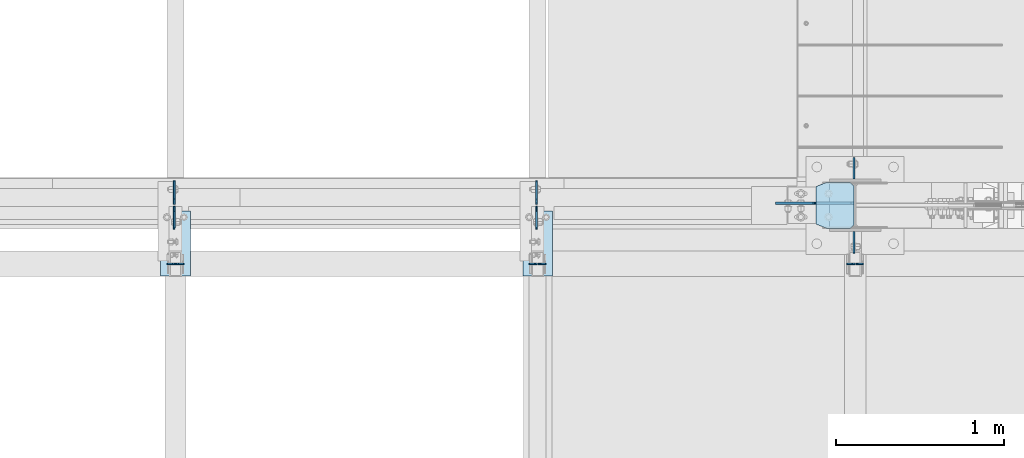
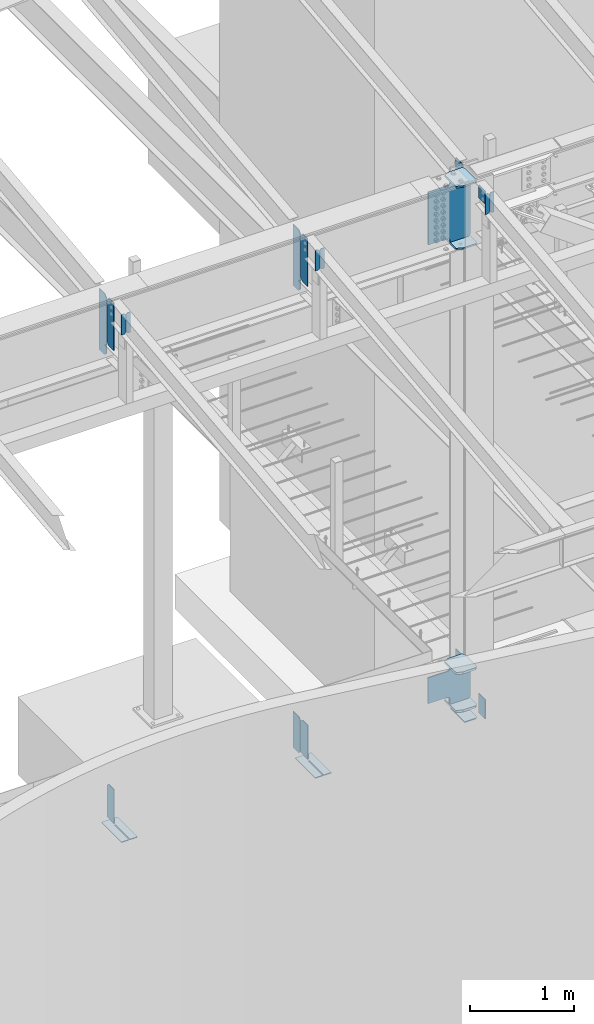
# One storey, part 997 of 1179: 26 plates, 8 elements without a shape of their own.
"""IFC2X3 building model written with IfcOpenShell, lengths in millimetres."""

from ifc_helpers import new_model, si_unit, frame, origin_with_axes, place, context, subcontext, project, spatial, faceted_brep, material, type_object, element, aggregate, save


model = new_model("IFC2X3")

# Units and contexts
model_context = context("Model", 3, precision=1e-05, world=origin_with_axes())
body_context = subcontext(model_context, "Body", "Model", "MODEL_VIEW")
ifc_project = project(units=[si_unit("LENGTHUNIT", "METRE", prefix="MILLI"), si_unit("AREAUNIT", "SQUARE_METRE"), si_unit("VOLUMEUNIT", "CUBIC_METRE"), si_unit("MASSUNIT", "GRAM", prefix="KILO"), si_unit("TIMEUNIT", "SECOND"), si_unit("PLANEANGLEUNIT", "RADIAN"), si_unit("SOLIDANGLEUNIT", "STERADIAN"), si_unit("THERMODYNAMICTEMPERATUREUNIT", "DEGREE_CELSIUS"), si_unit("LUMINOUSINTENSITYUNIT", "LUMEN")], contexts=[model_context])

# Site, building, storey
site_placement = place(None, origin_with_axes())
site = spatial("IfcSite", under=ifc_project, at=site_placement, CompositionType="ELEMENT")
building_placement = place(site_placement, origin_with_axes())
building = spatial("IfcBuilding", under=site, at=building_placement, Name="Undefined", CompositionType="ELEMENT")
storey_placement = place(building_placement, origin_with_axes())
storey = spatial("IfcBuildingStorey", under=building, at=storey_placement, Name="Undefined", CompositionType="ELEMENT", Elevation=0.0)

# Assembly, plates
assembly_1_placement = place(storey_placement, origin_with_axes())
assembly_1 = element("IfcElementAssembly", 1, at=assembly_1_placement, inside=storey, Name="COLUMN", AssemblyPlace="NOTDEFINED", PredefinedType="RIGID_FRAME")
ifc_material_1 = material(Name="STEEL/A36")
plate_type_1 = type_object("IfcPlateType", PredefinedType="NOTDEFINED")
plate_1_placement = place(assembly_1_placement, frame((16452.05625, 5592.76250000006, 9850.31550933372), z_axis=(0.0, 1.0, 0.0), x_axis=(0.0, 0.0, -1.0)))
plate_1 = element("IfcPlate", 2, at=plate_1_placement, type_object=plate_type_1, material=ifc_material_1, Name="PLATE", context=body_context, shape_type="Brep", body=[
    faceted_brep([(0.0, -4.76249999999709, 0.0), (0.0, -4.76249999999709, 127.0), (0.0, 4.76249999999709, 127.0), (0.0, 4.76249999999709, 0.0), (228.6, -4.76249999999709, 127.0), (228.6, 4.76249999999709, 127.0), (228.6, -4.76249999999709, 0.0), (228.6, 4.76249999999709, 0.0)], [[[0, 1, 2, 3]], [[1, 4, 5, 2]], [[4, 6, 7, 5]], [[6, 0, 3, 7]], [[5, 7, 3, 2]], [[6, 4, 1, 0]]]),
])
plate_2_placement = place(assembly_1_placement, frame((16452.05625, 5278.43749999996, 9794.70652310487), z_axis=(0.0, -1.0, 0.0), x_axis=(0.0, 0.0, -1.0)))
plate_2 = element("IfcPlate", 3, at=plate_2_placement, type_object=plate_type_1, material=ifc_material_1, Name="PLATE", context=body_context, shape_type="Brep", body=[
    faceted_brep([(0.0, -4.76249999999709, 0.0), (0.0, -4.76249999999709, 127.0), (0.0, 4.76249999999709, 127.0), (0.0, 4.76249999999709, 0.0), (152.4, -4.76250000000073, 127.0), (152.4, 4.76250000000073, 127.0), (152.4, -4.76250000000073, 0.0), (152.4, 4.76250000000073, 0.0)], [[[0, 1, 2, 3]], [[1, 4, 5, 2]], [[4, 6, 7, 5]], [[6, 0, 3, 7]], [[5, 7, 3, 2]], [[6, 4, 1, 0]]]),
])

assembly_2_placement = place(storey_placement, origin_with_axes())
assembly_2 = element("IfcElementAssembly", 4, at=assembly_2_placement, inside=storey, Name="BEAM", AssemblyPlace="NOTDEFINED", PredefinedType="RIGID_FRAME")
plate_3_placement = place(assembly_2_placement, frame((14559.7557500839, 5429.25933465636, 9245.8912842795), z_axis=(0.0, 0.0, 1.0), x_axis=(0.0, -1.0, 0.0)))
plate_3 = element("IfcPlate", 5, at=plate_3_placement, type_object=plate_type_1, material=ifc_material_1, Name="PLATE", context=body_context, shape_type="Brep", body=[
    faceted_brep([(1.81898940354586e-12, -4.76249999999709, 31.75), (0.0, -4.76250000000073, 531.8125), (0.0, 4.76250000000073, 531.8125), (-1.81898940354586e-12, 4.76249999998981, 31.75), (31.75, -4.76250000000073, 563.5625), (31.75, 4.76250000000073, 563.5625), (127.0, -4.76250000000073, 563.5625), (127.0, 4.76250000000073, 563.5625), (127.0, -4.76250000000073, 0.0), (127.0, 4.76250000000073, 0.0), (31.7499999988213, -4.76250000001164, 0.0), (31.7499999988249, 4.76249999998254, 0.0)], [[[0, 1, 2, 3]], [[1, 4, 5, 2]], [[4, 6, 7, 5]], [[6, 8, 9, 7]], [[8, 10, 11, 9]], [[10, 0, 3, 11]], [[5, 7, 9, 11, 3, 2]], [[10, 8, 6, 4, 1, 0]]]),
])
plate_4_placement = place(assembly_2_placement, frame((12400.7557500839, 5429.25933465636, 9245.8912842795), z_axis=(0.0, 0.0, 1.0), x_axis=(0.0, -1.0, 0.0)))
plate_4 = element("IfcPlate", 6, at=plate_4_placement, type_object=plate_type_1, material=ifc_material_1, Name="PLATE", context=body_context, shape_type="Brep", body=[
    faceted_brep([(1.81898940354586e-12, -4.76249999999709, 31.75), (0.0, -4.76250000000073, 531.8125), (0.0, 4.76250000000073, 531.8125), (-1.81898940354586e-12, 4.76249999998981, 31.75), (31.75, -4.76250000000073, 563.5625), (31.75, 4.76250000000073, 563.5625), (127.0, -4.76250000000073, 563.5625), (127.0, 4.76250000000073, 563.5625), (127.0, -4.76250000000073, 0.0), (127.0, 4.76250000000073, 0.0), (31.7499999988213, -4.76250000001164, 0.0), (31.7499999988249, 4.76249999998254, 0.0)], [[[0, 1, 2, 3]], [[1, 4, 5, 2]], [[4, 6, 7, 5]], [[6, 8, 9, 7]], [[8, 10, 11, 9]], [[10, 0, 3, 11]], [[5, 7, 9, 11, 3, 2]], [[10, 8, 6, 4, 1, 0]]]),
])

# Plate
plate_5_placement = place(assembly_1_placement, frame((16451.2625017882, 5278.43749999682, 3810.0), z_axis=(0.0, -1.0, 0.0), x_axis=(0.0, 0.0, -1.0)))
plate_5 = element("IfcPlate", 7, at=plate_5_placement, type_object=plate_type_1, material=ifc_material_1, Name="PLATE", context=body_context, shape_type="Brep", body=[
    faceted_brep([(0.0, -4.76249999999709, 0.0), (0.0, -4.76249999999709, 127.0), (0.0, 4.76249999999709, 127.0), (0.0, 4.76249999999709, 0.0), (228.6, -4.76249999999709, 127.0), (228.6, 4.76249999999709, 127.0), (228.6, -4.76249999999709, 0.0), (228.6, 4.76249999999709, 0.0)], [[[0, 1, 2, 3]], [[1, 4, 5, 2]], [[4, 6, 7, 5]], [[6, 0, 3, 7]], [[5, 7, 3, 2]], [[6, 4, 1, 0]]]),
])

plate_6_placement = place(assembly_1_placement, frame((16451.2625, 5592.7625, 4063.99999886453), z_axis=(0.0, 1.0, 0.0), x_axis=(0.0, 0.0, -1.0)))
plate_6 = element("IfcPlate", 8, at=plate_6_placement, type_object=plate_type_1, material=ifc_material_1, Name="PLATE", context=body_context, shape_type="Brep", body=[
    faceted_brep([(0.0, -4.76249999999709, 0.0), (0.0, -4.76249999999709, 127.0), (0.0, 4.76249999999709, 127.0), (0.0, 4.76249999999709, 0.0), (304.799999999999, -4.76249999999982, 127.0), (304.799999999999, 4.76249999999982, 127.0), (304.799987792969, -4.76250000000073, 0.0), (304.799987792969, 4.76250000000073, 0.0)], [[[0, 1, 2, 3]], [[2, 1, 4, 5]], [[4, 6, 7, 5]], [[6, 0, 3, 7]], [[5, 7, 3, 2]], [[6, 4, 1, 0]]]),
])

# Assembly, plates
assembly_3_placement = place(storey_placement, origin_with_axes())
assembly_3 = element("IfcElementAssembly", 9, at=assembly_3_placement, inside=storey, Name="BEAM", AssemblyPlace="NOTDEFINED", PredefinedType="RIGID_FRAME")
plate_type_2 = type_object("IfcPlateType", PredefinedType="NOTDEFINED")
plate_7_placement = place(assembly_3_placement, frame((14558.9624967425, 5576.9753907878, 3652.8375), z_axis=(0.0, 0.0, 1.0), x_axis=(0.0, -1.0, 0.0)))
plate_7 = element("IfcPlate", 10, at=plate_7_placement, type_object=plate_type_2, material=ifc_material_1, Name="PLATE", context=body_context, shape_type="Brep", body=[
    faceted_brep([(0.0, -4.76249999999709, 0.0), (-9.09494701772928e-13, -4.76250000000255, 425.450012207031), (9.09494701772928e-13, 4.76249999999891, 425.450012207031), (0.0, 4.76249999999709, 0.0), (108.743890762328, -4.76250000002983, 425.450012207031), (108.743890762331, 4.7624999999698, 425.450012207031), (134.143890380858, -4.76250000003529, 400.050012588501), (134.143890380861, 4.76249999996435, 400.050012588501), (134.143890380858, -4.76250000003529, 25.3999996185303), (134.143890380861, 4.76249999996435, 25.3999996185303), (108.743890762328, -4.76250000002983, 0.0), (108.743890762331, 4.7624999999698, 0.0)], [[[0, 1, 2, 3]], [[1, 4, 5, 2]], [[4, 6, 7, 5]], [[6, 8, 9, 7]], [[8, 10, 11, 9]], [[10, 0, 3, 11]], [[5, 7, 9, 11, 3, 2]], [[10, 8, 6, 4, 1, 0]]]),
])
plate_8_placement = place(assembly_3_placement, frame((14558.9624998093, 5294.3125001143, 3683.00001220703), z_axis=(0.0, 0.0, 1.0), x_axis=(0.0, 1.0, 0.0)))
plate_8 = element("IfcPlate", 11, at=plate_8_placement, type_object=plate_type_2, material=ifc_material_1, Name="PLATE", context=body_context, shape_type="Brep", body=[
    faceted_brep([(0.0, -4.76249999999709, 0.0), (1.81898940354586e-12, -4.76250000000437, 396.875), (0.0, 4.762500000008, 396.875), (0.0, 4.76249999999709, 0.0), (108.74389076233, -4.76249999996799, 396.875), (108.743890762327, 4.76250000003165, 396.875), (134.14389038086, -4.76249999996253, 371.47500038147), (134.143890380858, 4.76250000003711, 371.47500038147), (134.14389038086, -4.76249999996253, 0.0), (134.143890380858, 4.76250000003711, 0.0)], [[[0, 1, 2, 3]], [[1, 4, 5, 2]], [[4, 6, 7, 5]], [[6, 8, 9, 7]], [[8, 0, 3, 9]], [[5, 7, 9, 3, 2]], [[8, 6, 4, 1, 0]]]),
])
plate_9_placement = place(assembly_3_placement, frame((12399.9624967425, 5294.3125001143, 3683.00001220703), z_axis=(0.0, 0.0, 1.0), x_axis=(0.0, 1.0, 0.0)))
plate_9 = element("IfcPlate", 12, at=plate_9_placement, type_object=plate_type_2, material=ifc_material_1, Name="PLATE", context=body_context, shape_type="Brep", body=[
    faceted_brep([(0.0, -4.76249999999709, 0.0), (1.81898940354586e-12, -4.76250000000437, 396.875), (0.0, 4.762500000008, 396.875), (0.0, 4.76249999999709, 0.0), (108.74389076233, -4.76249999996799, 396.875), (108.743890762327, 4.76250000003165, 396.875), (134.14389038086, -4.76249999996253, 371.47500038147), (134.143890380858, 4.76250000003711, 371.47500038147), (134.14389038086, -4.76249999996253, 0.0), (134.143890380858, 4.76250000003711, 0.0)], [[[0, 1, 2, 3]], [[1, 4, 5, 2]], [[4, 6, 7, 5]], [[6, 8, 9, 7]], [[8, 0, 3, 9]], [[5, 7, 9, 3, 2]], [[8, 6, 4, 1, 0]]]),
])
aggregate(assembly_3, [plate_7, plate_8, plate_9])

# Plate
plate_type_3 = type_object("IfcPlateType", PredefinedType="NOTDEFINED")
plate_10_placement = place(assembly_2_placement, frame((14559.7557500839, 5441.95933465636, 9095.0787842795), z_axis=(0.0, 0.0, 1.0), x_axis=(0.0, 1.0, 0.0)))
plate_10 = element("IfcPlate", 13, at=plate_10_placement, type_object=plate_type_3, material=ifc_material_1, Name="PLATE", context=body_context, shape_type="Brep", body=[
    faceted_brep([(1.81898940354586e-12, -4.76249999999709, 31.75), (0.0, -4.76249999999982, 682.625), (0.0, 4.76249999999982, 682.625), (-1.81898940354586e-12, 4.76249999998981, 31.75), (31.75, -4.76249999999982, 714.375), (31.75, 4.76249999999982, 714.375), (139.7, -4.76249999999982, 714.375), (139.7, 4.76249999999982, 714.375), (139.7, -4.76249999999982, 0.0), (139.7, 4.76249999999982, 0.0), (31.7499999988213, -4.76250000001164, 0.0), (31.7499999988249, 4.76249999998254, 0.0)], [[[0, 1, 2, 3]], [[1, 4, 5, 2]], [[4, 6, 7, 5]], [[6, 8, 9, 7]], [[8, 10, 11, 9]], [[10, 0, 3, 11]], [[5, 7, 9, 11, 3, 2]], [[10, 8, 6, 4, 1, 0]]]),
])

plate_11_placement = place(assembly_2_placement, frame((12400.7557500839, 5441.95933465636, 9095.0787842795), z_axis=(0.0, 0.0, 1.0), x_axis=(0.0, 1.0, 0.0)))
plate_11 = element("IfcPlate", 14, at=plate_11_placement, type_object=plate_type_3, material=ifc_material_1, Name="PLATE", context=body_context, shape_type="Brep", body=[
    faceted_brep([(1.81898940354586e-12, -4.76249999999709, 31.75), (0.0, -4.76249999999982, 682.625), (0.0, 4.76249999999982, 682.625), (-1.81898940354586e-12, 4.76249999998981, 31.75), (31.75, -4.76249999999982, 714.375), (31.75, 4.76249999999982, 714.375), (139.7, -4.76249999999982, 714.375), (139.7, 4.76249999999982, 714.375), (139.7, -4.76249999999982, 0.0), (139.7, 4.76249999999982, 0.0), (31.7499999988213, -4.76250000001164, 0.0), (31.7499999988249, 4.76249999998254, 0.0)], [[[0, 1, 2, 3]], [[1, 4, 5, 2]], [[4, 6, 7, 5]], [[6, 8, 9, 7]], [[8, 10, 11, 9]], [[10, 0, 3, 11]], [[5, 7, 9, 11, 3, 2]], [[10, 8, 6, 4, 1, 0]]]),
])

aggregate(assembly_2, [plate_3, plate_10, plate_4, plate_11])

# Assembly, plate
assembly_4_placement = place(storey_placement, origin_with_axes())
assembly_4 = element("IfcElementAssembly", 15, at=assembly_4_placement, inside=storey, Name="BEAM", AssemblyPlace="NOTDEFINED", PredefinedType="RIGID_FRAME")
plate_type_4 = type_object("IfcPlateType", PredefinedType="NOTDEFINED")
plate_12_placement = place(assembly_4_placement, frame((14655.8000024381, 5403.05638849583, 3656.0125), z_axis=(0.0, -1.0, 0.0), x_axis=(-1.0, 0.0, 0.0)))
plate_12 = element("IfcPlate", 16, at=plate_12_placement, type_object=plate_type_4, material=ifc_material_1, Name="PLATE", context=body_context, shape_type="Brep", body=[
    faceted_brep([(84.1374995226361, -4.76249999999982, 388.143896484398), (84.1374998016308, -4.76249999999982, 108.743890683401), (84.1374998016308, 4.76249999999982, 108.743890683401), (84.1374995226361, 4.76249999999982, 388.143896484398), (93.6624994201611, -4.76249999999982, 108.743890698304), (93.6624994201611, 4.76249999999982, 108.743890698304), (93.6624981874847, -4.76249999999982, 388.143890669526), (93.6624981874847, 4.76249999999982, 388.143896484401), (0.0, -4.76249999999709, 0.0), (-1.44472687679809e-06, -4.76249999999982, 388.143896484375), (-1.44472687679809e-06, 4.76249999999982, 388.143896484375), (0.0, 4.76249999999709, 0.0), (177.800003051758, -4.76249999999982, 0.0), (177.800003051758, 4.76249999999982, 0.0), (177.799987133836, -4.76249999999982, 388.143896484426), (177.799987133836, 4.76249999999982, 388.143896484426)], [[[0, 1, 2, 3]], [[4, 5, 2, 1]], [[6, 7, 5, 4]], [[8, 9, 10, 11]], [[12, 8, 11, 13]], [[14, 12, 13, 15]], [[1, 0, 9, 8, 12, 14, 6, 4]], [[10, 9, 0, 3]], [[15, 13, 11, 10, 3, 2, 5, 7]], [[14, 15, 7, 6]]]),
])
aggregate(assembly_4, [plate_12])

assembly_5_placement = place(storey_placement, origin_with_axes())
assembly_5 = element("IfcElementAssembly", 17, at=assembly_5_placement, inside=storey, Name="BEAM", AssemblyPlace="NOTDEFINED", PredefinedType="RIGID_FRAME")
plate_13_placement = place(assembly_5_placement, frame((12496.7999993714, 5403.05638849583, 3656.0125), z_axis=(0.0, -1.0, 0.0), x_axis=(-1.0, 0.0, 0.0)))
plate_13 = element("IfcPlate", 18, at=plate_13_placement, type_object=plate_type_4, material=ifc_material_1, Name="PLATE", context=body_context, shape_type="Brep", body=[
    faceted_brep([(84.1374995226361, -4.76249999999982, 388.143896484398), (84.1374998016308, -4.76249999999982, 108.743890683401), (84.1374998016308, 4.76249999999982, 108.743890683401), (84.1374995226361, 4.76249999999982, 388.143896484398), (93.6624994201611, -4.76249999999982, 108.743890698304), (93.6624994201611, 4.76249999999982, 108.743890698304), (93.6624981874847, -4.76249999999982, 388.143890669526), (93.6624981874847, 4.76249999999982, 388.143896484401), (0.0, -4.76249999999709, 0.0), (-1.44472687679809e-06, -4.76249999999982, 388.143896484375), (-1.44472687679809e-06, 4.76249999999982, 388.143896484375), (0.0, 4.76249999999709, 0.0), (177.800003051758, -4.76249999999982, 0.0), (177.800003051758, 4.76249999999982, 0.0), (177.799987133836, -4.76249999999982, 388.143896484426), (177.799987133836, 4.76249999999982, 388.143896484426)], [[[0, 1, 2, 3]], [[4, 5, 2, 1]], [[6, 7, 5, 4]], [[8, 9, 10, 11]], [[12, 8, 11, 13]], [[14, 12, 13, 15]], [[1, 0, 9, 8, 12, 14, 6, 4]], [[10, 9, 0, 3]], [[15, 13, 11, 10, 3, 2, 5, 7]], [[14, 15, 7, 6]]]),
])
aggregate(assembly_5, [plate_13])

# Assembly, plates
assembly_6_placement = place(storey_placement, origin_with_axes())
assembly_6 = element("IfcElementAssembly", 19, at=assembly_6_placement, inside=storey, Name="BEAM", AssemblyPlace="NOTDEFINED", PredefinedType="RIGID_FRAME")
plate_type_5 = type_object("IfcPlateType", PredefinedType="NOTDEFINED")
plate_14_placement = place(assembly_6_placement, frame((16409.9875, 5086.35, 9814.71314162917), z_axis=(0.0, 0.0, -1.0), x_axis=(1.0, 0.0, 0.0)))
plate_14 = element("IfcPlate", 20, at=plate_14_placement, type_object=plate_type_5, material=ifc_material_1, Name="PLATE", context=body_context, shape_type="Brep", body=[
    faceted_brep([(0.0, -4.76249999999709, 0.0), (0.0, -4.76249999999982, 240.171811375247), (0.0, 4.76249999999982, 240.171811375247), (0.0, 4.76249999999709, 0.0), (30.9562500000029, -4.76249999999982, 240.171811375247), (30.9562500000029, 4.76249999999982, 240.171811375247), (46.8312500000029, -4.76249999999982, 224.296811375247), (46.8312500000029, 4.76249999999982, 224.296811375247), (46.8312500000029, -4.76249999999982, 15.875), (46.8312500000029, 4.76249999999982, 15.875), (30.9562500000029, -4.76249999999982, 0.0), (30.9562500000029, 4.76249999999982, 0.0)], [[[0, 1, 2, 3]], [[1, 4, 5, 2]], [[4, 6, 7, 5]], [[6, 8, 9, 7]], [[8, 10, 11, 9]], [[10, 0, 3, 11]], [[5, 7, 9, 11, 3, 2]], [[10, 8, 6, 4, 1, 0]]]),
])
plate_15_placement = place(assembly_6_placement, frame((16461.58125, 5086.35, 9814.71314162917), z_axis=(0.0, 0.0, -1.0), x_axis=(1.0, 0.0, 0.0)))
plate_15 = element("IfcPlate", 21, at=plate_15_placement, type_object=plate_type_5, material=ifc_material_1, Name="PLATE", context=body_context, shape_type="Brep", body=[
    faceted_brep([(-1.81898940354586e-12, -4.76249999999936, 15.875), (0.0, -4.76249999999982, 224.296811375247), (0.0, 4.76249999999982, 224.296811375247), (1.81898940354586e-12, 4.76249999999936, 15.875), (15.875, -4.76249999999982, 240.171811375247), (15.875, 4.76249999999982, 240.171811375247), (46.8312500000029, -4.76249999999982, 240.171811375247), (46.8312500000029, 4.76249999999982, 240.171811375247), (46.8312500000029, -4.76249999999982, 0.0), (46.8312500000029, 4.76249999999982, 0.0), (15.8749999999891, -4.76249999999845, 0.0), (15.8749999999945, 4.76250000000027, 0.0)], [[[0, 1, 2, 3]], [[1, 4, 5, 2]], [[4, 6, 7, 5]], [[6, 8, 9, 7]], [[8, 10, 11, 9]], [[10, 0, 3, 11]], [[5, 7, 9, 11, 3, 2]], [[10, 8, 6, 4, 1, 0]]]),
])
aggregate(assembly_6, [plate_14, plate_15])

assembly_7_placement = place(storey_placement, origin_with_axes())
assembly_7 = element("IfcElementAssembly", 22, at=assembly_7_placement, inside=storey, Name="BEAM", AssemblyPlace="NOTDEFINED", PredefinedType="RIGID_FRAME")
plate_16_placement = place(assembly_7_placement, frame((14517.6875, 5086.35, 9814.71314162916), z_axis=(0.0, 0.0, -1.0), x_axis=(1.0, 0.0, 0.0)))
plate_16 = element("IfcPlate", 23, at=plate_16_placement, type_object=plate_type_5, material=ifc_material_1, Name="PLATE", context=body_context, shape_type="Brep", body=[
    faceted_brep([(0.0, -4.76249999999709, 0.0), (0.0, -4.76249999999982, 240.171811375247), (0.0, 4.76249999999982, 240.171811375247), (0.0, 4.76249999999709, 0.0), (30.9562500000029, -4.76249999999982, 240.171811375247), (30.9562500000029, 4.76249999999982, 240.171811375247), (46.8312500000029, -4.76249999999982, 224.296811375247), (46.8312500000029, 4.76249999999982, 224.296811375247), (46.8312500000029, -4.76249999999982, 15.875), (46.8312500000029, 4.76249999999982, 15.875), (30.9562500000029, -4.76249999999982, 0.0), (30.9562500000029, 4.76249999999982, 0.0)], [[[0, 1, 2, 3]], [[1, 4, 5, 2]], [[4, 6, 7, 5]], [[6, 8, 9, 7]], [[8, 10, 11, 9]], [[10, 0, 3, 11]], [[5, 7, 9, 11, 3, 2]], [[10, 8, 6, 4, 1, 0]]]),
])
plate_17_placement = place(assembly_7_placement, frame((14569.28125, 5086.35, 9814.71314162916), z_axis=(0.0, 0.0, -1.0), x_axis=(1.0, 0.0, 0.0)))
plate_17 = element("IfcPlate", 24, at=plate_17_placement, type_object=plate_type_5, material=ifc_material_1, Name="PLATE", context=body_context, shape_type="Brep", body=[
    faceted_brep([(-1.81898940354586e-12, -4.76249999999936, 15.875), (0.0, -4.76249999999982, 224.296811375247), (0.0, 4.76249999999982, 224.296811375247), (1.81898940354586e-12, 4.76249999999936, 15.875), (15.875, -4.76249999999982, 240.171811375247), (15.875, 4.76249999999982, 240.171811375247), (46.8312500000029, -4.76249999999982, 240.171811375247), (46.8312500000029, 4.76249999999982, 240.171811375247), (46.8312500000029, -4.76249999999982, 0.0), (46.8312500000029, 4.76249999999982, 0.0), (15.8749999999891, -4.76249999999845, 0.0), (15.8749999999945, 4.76250000000027, 0.0)], [[[0, 1, 2, 3]], [[1, 4, 5, 2]], [[4, 6, 7, 5]], [[6, 8, 9, 7]], [[8, 10, 11, 9]], [[10, 0, 3, 11]], [[5, 7, 9, 11, 3, 2]], [[10, 8, 6, 4, 1, 0]]]),
])
aggregate(assembly_7, [plate_16, plate_17])

assembly_8_placement = place(storey_placement, origin_with_axes())
assembly_8 = element("IfcElementAssembly", 25, at=assembly_8_placement, inside=storey, Name="BEAM", AssemblyPlace="NOTDEFINED", PredefinedType="RIGID_FRAME")
plate_18_placement = place(assembly_8_placement, frame((12358.6875, 5086.35, 9814.71314162916), z_axis=(0.0, 0.0, -1.0), x_axis=(1.0, 0.0, 0.0)))
plate_18 = element("IfcPlate", 26, at=plate_18_placement, type_object=plate_type_5, material=ifc_material_1, Name="PLATE", context=body_context, shape_type="Brep", body=[
    faceted_brep([(0.0, -4.76249999999709, 0.0), (0.0, -4.76249999999982, 240.171811375247), (0.0, 4.76249999999982, 240.171811375247), (0.0, 4.76249999999709, 0.0), (30.9562500000029, -4.76249999999982, 240.171811375247), (30.9562500000029, 4.76249999999982, 240.171811375247), (46.8312500000029, -4.76249999999982, 224.296811375247), (46.8312500000029, 4.76249999999982, 224.296811375247), (46.8312500000029, -4.76249999999982, 15.875), (46.8312500000029, 4.76249999999982, 15.875), (30.9562500000029, -4.76249999999982, 0.0), (30.9562500000029, 4.76249999999982, 0.0)], [[[0, 1, 2, 3]], [[1, 4, 5, 2]], [[4, 6, 7, 5]], [[6, 8, 9, 7]], [[8, 10, 11, 9]], [[10, 0, 3, 11]], [[5, 7, 9, 11, 3, 2]], [[10, 8, 6, 4, 1, 0]]]),
])
plate_19_placement = place(assembly_8_placement, frame((12410.28125, 5086.35, 9814.71314162916), z_axis=(0.0, 0.0, -1.0), x_axis=(1.0, 0.0, 0.0)))
plate_19 = element("IfcPlate", 27, at=plate_19_placement, type_object=plate_type_5, material=ifc_material_1, Name="PLATE", context=body_context, shape_type="Brep", body=[
    faceted_brep([(-1.81898940354586e-12, -4.76249999999936, 15.875), (0.0, -4.76249999999982, 224.296811375247), (0.0, 4.76249999999982, 224.296811375247), (1.81898940354586e-12, 4.76249999999936, 15.875), (15.875, -4.76249999999982, 240.171811375247), (15.875, 4.76249999999982, 240.171811375247), (46.8312500000029, -4.76249999999982, 240.171811375247), (46.8312500000029, 4.76249999999982, 240.171811375247), (46.8312500000029, -4.76249999999982, 0.0), (46.8312500000029, 4.76249999999982, 0.0), (15.8749999999891, -4.76249999999845, 0.0), (15.8749999999945, 4.76250000000027, 0.0)], [[[0, 1, 2, 3]], [[1, 4, 5, 2]], [[4, 6, 7, 5]], [[6, 8, 9, 7]], [[8, 10, 11, 9]], [[10, 0, 3, 11]], [[5, 7, 9, 11, 3, 2]], [[10, 8, 6, 4, 1, 0]]]),
])
aggregate(assembly_8, [plate_18, plate_19])

# Plate
ifc_material_2 = material(Name="STEEL/A572-GR.50")
plate_type_6 = type_object("IfcPlateType", PredefinedType="NOTDEFINED")
plate_20_placement = place(assembly_1_placement, frame((16224.25, 5572.125, 9087.14128428836), z_axis=(0.0, -1.0, 0.0), x_axis=(1.0, 0.0, 0.0)))
plate_20 = element("IfcPlate", 28, at=plate_20_placement, type_object=plate_type_6, material=ifc_material_2, Name="PLATE", context=body_context, shape_type="Brep", body=[
    faceted_brep([(0.0, -9.52499999999964, 25.3999996185303), (0.0, -9.52499999999964, 247.65000038147), (0.0, 9.52499999999964, 247.65000038147), (0.0, 9.52499999999964, 25.3999996185303), (61.9124984741211, -9.52499999999964, 273.05), (61.9124984741211, 9.52499999999964, 273.05), (206.374999618529, -9.52499999999964, 273.049999999996), (206.374999618529, 9.52499999999964, 273.049999999996), (228.599999999999, -9.52499999999964, 250.824999618526), (228.599999999999, 9.52499999999964, 250.824999618526), (228.599999999999, -9.52499999999964, 22.2250003814697), (228.599999999999, 9.52499999999964, 22.2250003814697), (206.374999618529, -9.52499999999964, 0.0), (206.374999618529, 9.52499999999964, 0.0), (61.9124984741211, -9.52499999999964, 9.09494701772928e-13), (61.9124984741211, 9.52499999999964, 9.09494701772928e-13)], [[[0, 1, 2, 3]], [[1, 4, 5, 2]], [[4, 6, 7, 5]], [[6, 8, 9, 7]], [[8, 10, 11, 9]], [[10, 12, 13, 11]], [[12, 14, 15, 13]], [[14, 0, 3, 15]], [[5, 7, 9, 11, 13, 15, 3, 2]], [[14, 12, 10, 8, 6, 4, 1, 0]]]),
])

plate_21_placement = place(assembly_1_placement, frame((16224.25, 5572.125, 9817.39128428836), z_axis=(0.0, -1.0, 0.0), x_axis=(1.0, 0.0, 0.0)))
plate_21 = element("IfcPlate", 29, at=plate_21_placement, type_object=plate_type_6, material=ifc_material_2, Name="PLATE", context=body_context, shape_type="Brep", body=[
    faceted_brep([(0.0, -9.52499999999964, 25.3999996185303), (0.0, -9.52499999999964, 247.65000038147), (0.0, 9.52499999999964, 247.65000038147), (0.0, 9.52499999999964, 25.3999996185303), (61.9124984741211, -9.52499999999964, 273.05), (61.9124984741211, 9.52499999999964, 273.05), (206.374999618529, -9.52499999999964, 273.049999999996), (206.374999618529, 9.52499999999964, 273.049999999996), (228.599999999999, -9.52499999999964, 250.824999618526), (228.599999999999, 9.52499999999964, 250.824999618526), (228.599999999999, -9.52499999999964, 22.2250003814697), (228.599999999999, 9.52499999999964, 22.2250003814697), (206.374999618529, -9.52499999999964, 0.0), (206.374999618529, 9.52499999999964, 0.0), (61.9124984741211, -9.52499999999964, 9.09494701772928e-13), (61.9124984741211, 9.52499999999964, 9.09494701772928e-13)], [[[0, 1, 2, 3]], [[1, 4, 5, 2]], [[4, 6, 7, 5]], [[6, 8, 9, 7]], [[8, 10, 11, 9]], [[10, 12, 13, 11]], [[12, 14, 15, 13]], [[14, 0, 3, 15]], [[5, 7, 9, 11, 13, 15, 3, 2]], [[14, 12, 10, 8, 6, 4, 1, 0]]]),
])

plate_type_7 = type_object("IfcPlateType", PredefinedType="NOTDEFINED")
plate_22_placement = place(assembly_1_placement, frame((16306.8, 5572.125, 3502.025), z_axis=(0.0, -1.0, 0.0), x_axis=(1.0, 0.0, 0.0)))
plate_22 = element("IfcPlate", 30, at=plate_22_placement, type_object=plate_type_7, material=ifc_material_1, Name="PLATE", context=body_context, shape_type="Brep", body=[
    faceted_brep([(0.0, -6.34999999999854, 0.0), (0.0, -6.34999999999991, 273.05), (0.0, 6.34999999999991, 273.05), (0.0, 6.34999999999854, 0.0), (123.824999618599, -6.34999999999991, 273.05), (123.824999618599, 6.34999999999991, 273.05), (146.050000000068, -6.34999999999991, 250.82499961853), (146.050000000068, 6.34999999999991, 250.82499961853), (146.050000000068, -6.34999999999991, 22.2250003814697), (146.050000000068, 6.34999999999991, 22.2250003814697), (123.824999618599, -6.34999999999991, 0.0), (123.824999618599, 6.34999999999991, 0.0)], [[[0, 1, 2, 3]], [[1, 4, 5, 2]], [[4, 6, 7, 5]], [[6, 8, 9, 7]], [[8, 10, 11, 9]], [[10, 0, 3, 11]], [[5, 7, 9, 11, 3, 2]], [[10, 8, 6, 4, 1, 0]]]),
])

plate_type_8 = type_object("IfcPlateType", PredefinedType="NOTDEFINED")
plate_23_placement = place(assembly_1_placement, frame((16224.25, 5572.125, 3641.725), z_axis=(0.0, -1.0, 0.0), x_axis=(1.0, 0.0, 0.0)))
plate_23 = element("IfcPlate", 31, at=plate_23_placement, type_object=plate_type_8, material=ifc_material_2, Name="PLATE", context=body_context, shape_type="Brep", body=[
    faceted_brep([(63.5, -12.6999999999998, 273.05), (63.5, 12.6999999999998, 273.05), (0.0, 12.6999999999998, 247.65000038147), (0.0, -12.6999999999998, 247.65000038147), (63.5, -12.6999999999998, 0.0), (0.0, -12.6999999999998, 25.3999996185303), (0.0, 12.6999999999998, 25.3999996185303), (63.5, 12.6999999999998, 0.0), (206.374999618531, 12.6999999999998, 0.0), (206.374999618531, -12.6999999999998, 0.0), (228.6, -12.6999999999998, 22.2250003814697), (228.6, 12.6999999999998, 22.2250003814697), (228.600000000002, -12.6999999999998, 250.82499961853), (228.600000000002, 12.6999999999998, 250.82499961853), (206.374999618532, -12.6999999999998, 273.05), (206.374999618532, 12.6999999999998, 273.05)], [[[0, 1, 2, 3]], [[4, 5, 6, 7]], [[8, 9, 4, 7]], [[10, 9, 8, 11]], [[12, 10, 11, 13]], [[14, 12, 13, 15]], [[5, 4, 9, 10, 12, 14, 0, 3]], [[6, 5, 3, 2]], [[15, 13, 11, 8, 7, 6, 2, 1]], [[14, 15, 1, 0]]]),
])

plate_24_placement = place(assembly_1_placement, frame((16224.25, 5572.125, 4089.4), z_axis=(0.0, -1.0, 0.0), x_axis=(1.0, 0.0, 0.0)))
plate_24 = element("IfcPlate", 32, at=plate_24_placement, type_object=plate_type_8, material=ifc_material_2, Name="PLATE", context=body_context, shape_type="Brep", body=[
    faceted_brep([(63.5, -12.6999999999998, 273.05), (63.5, 12.6999999999998, 273.05), (0.0, 12.6999999999998, 247.65000038147), (0.0, -12.6999999999998, 247.65000038147), (63.5, -12.6999999999998, 0.0), (0.0, -12.6999999999998, 25.3999996185303), (0.0, 12.6999999999998, 25.3999996185303), (63.5, 12.6999999999998, 0.0), (206.374999618531, 12.6999999999998, 0.0), (206.374999618531, -12.6999999999998, 0.0), (228.6, -12.6999999999998, 22.2250003814697), (228.6, 12.6999999999998, 22.2250003814697), (228.600000000002, -12.6999999999998, 250.82499961853), (228.600000000002, 12.6999999999998, 250.82499961853), (206.374999618532, -12.6999999999998, 273.05), (206.374999618532, 12.6999999999998, 273.05)], [[[0, 1, 2, 3]], [[4, 5, 6, 7]], [[8, 9, 4, 7]], [[10, 9, 8, 11]], [[12, 10, 11, 13]], [[14, 12, 13, 15]], [[5, 4, 9, 10, 12, 14, 0, 3]], [[6, 5, 3, 2]], [[15, 13, 11, 8, 7, 6, 2, 1]], [[14, 15, 1, 0]]]),
])

plate_type_9 = type_object("IfcPlateType", PredefinedType="NOTDEFINED")
plate_25_placement = place(assembly_1_placement, frame((16452.8499999535, 5449.09375009537, 3673.47500340641), z_axis=(-0.707106781186532, 0.0, 0.707106781186563), x_axis=(-0.707106781186564, 0.0, -0.707106781186531)))
plate_25 = element("IfcPlate", 33, at=plate_25_placement, type_object=plate_type_9, material=ifc_material_2, Name="PLATE", context=body_context, shape_type="Brep", body=[
    faceted_brep([(0.0, -6.34999999999854, 0.0), (-271.652749686205, -6.35000000000036, 271.652745638487), (-271.652749686205, 6.35000000000036, 271.652745638487), (0.0, 6.34999999999854, 0.0), (-271.652749686187, -6.35000000000036, 298.59351380097), (-271.652749686187, 6.35000000000036, 298.59351380097), (-123.478521665553, -6.34999999999854, 446.767742022512), (-123.478521665553, 6.34999999999854, 446.767742022512), (-115.238170140661, -6.35000000000036, 441.261709882992), (-115.238170140661, 6.35000000000036, 441.261709882992), (-105.518011090155, -6.35000000000036, 439.328250110237), (-105.518011090155, 6.35000000000036, 439.328250110237), (-95.7978520684592, -6.35000000000036, 441.261710027846), (-95.7978520684592, 6.35000000000036, 441.261710027846), (-87.5574991731719, -6.35000000000036, 446.767737890217), (-87.5574991731719, 6.35000000000036, 446.767737890217), (65.106858064988, -6.35000000000036, 599.432097403813), (65.106858064988, 6.35000000000036, 599.432097403813), (280.633006576354, -6.35000000000036, 383.905952103711), (280.633006576354, 6.35000000000036, 383.905952103711), (127.968649338123, -6.35000000000036, 231.241592590048), (127.968649338123, 6.35000000000036, 231.241592590048), (122.462621598579, -6.35000000000036, 223.001239612715), (122.462621598579, 6.35000000000036, 223.001239612715), (120.529161825836, -6.35000000000036, 213.281080562227), (120.529161825836, 6.35000000000036, 213.281080562227), (122.462621743432, -6.35000000000036, 203.560921540546), (122.462621743432, 6.35000000000036, 203.560921540546), (127.968649605775, -6.35000000000036, 195.320568645267), (127.968649605775, 6.35000000000036, 195.320568645267), (175.114994360907, -6.34999999999854, 148.174225997692), (175.114994360907, 6.34999999999854, 148.174225997692), (26.9407683631471, -6.34999999999854, -6.91215973347425e-11), (26.9407683631471, 6.34999999999854, -6.91215973347425e-11)], [[[0, 1, 2, 3]], [[1, 4, 5, 2]], [[4, 6, 7, 5]], [[6, 8, 9, 7]], [[8, 10, 11, 9]], [[10, 12, 13, 11]], [[12, 14, 15, 13]], [[14, 16, 17, 15]], [[16, 18, 19, 17]], [[18, 20, 21, 19]], [[20, 22, 23, 21]], [[22, 24, 25, 23]], [[24, 26, 27, 25]], [[26, 28, 29, 27]], [[28, 30, 31, 29]], [[30, 32, 33, 31]], [[32, 0, 3, 33]], [[5, 7, 9, 11, 13, 15, 17, 19, 21, 23, 25, 27, 29, 31, 33, 3, 2]], [[32, 30, 28, 26, 24, 22, 20, 18, 16, 14, 12, 10, 8, 6, 4, 1, 0]]]),
])

plate_type_10 = type_object("IfcPlateType", PredefinedType="NOTDEFINED")
plate_26_placement = place(assembly_1_placement, frame((16452.8499999762, 5448.30933465636, 9115.71628759129), z_axis=(-0.707106781186532, 0.0, 0.707106781186563), x_axis=(-0.707106781186564, 0.0, -0.707106781186531)))
plate_26 = element("IfcPlate", 34, at=plate_26_placement, type_object=plate_type_10, material=ifc_material_2, Name="PLATE", context=body_context, shape_type="Brep", body=[
    faceted_brep([(0.0, -6.34999999999854, 0.0), (-475.953577962297, -6.35000000000036, 475.953570871354), (-475.953577962297, 6.35000000000036, 475.953570871354), (0.0, 6.34999999999854, 0.0), (-475.953577962297, -6.35000000000036, 502.894339033878), (-475.953577962297, 6.35000000000036, 502.894339033878), (-327.779351663696, -6.35000000000036, 651.068563124866), (-327.779351663696, 6.35000000000036, 651.068563124866), (-318.799095212296, -6.35000000000036, 642.08830680726), (-318.799095212296, 6.35000000000036, 642.08830680726), (-310.55874223496, -6.35000000000036, 636.582279067682), (-310.55874223496, 6.35000000000036, 636.582279067682), (-300.838583184446, -6.35000000000036, 634.648819294918), (-300.838583184446, 6.35000000000036, 634.648819294918), (-291.118424162742, -6.35000000000036, 636.58227921252), (-291.118424162742, 6.35000000000036, 636.58227921252), (-282.878071267449, -6.35000000000036, 642.08830707489), (-282.878071267449, 6.35000000000036, 642.08830707489), (-130.213711252516, -6.35000000000036, 794.752669365062), (-130.213711252516, 6.35000000000036, 794.752669365062), (309.818836176988, -6.34999999999854, 354.720116782351), (309.818836176988, 6.34999999999854, 354.720116782351), (157.15448184902, -6.34999999999854, 202.055762454381), (157.15448184902, 6.34999999999854, 202.055762454381), (151.648454048061, -6.34999999999854, 193.815409518072), (151.648454048061, 6.34999999999854, 193.815409518072), (149.714994202886, -6.34999999999854, 184.095250481979), (149.714994202886, 6.34999999999854, 184.095250481979), (151.648454048061, -6.34999999999854, 174.375091445886), (151.648454048061, 6.34999999999854, 174.375091445886), (157.154481849018, -6.34999999999854, 166.134738509576), (157.154481849018, 6.34999999999854, 166.134738509576), (175.114994360907, -6.34999999999854, 148.174225997692), (175.114994360907, 6.34999999999854, 148.174225997692), (26.9407683631471, -6.34999999999854, -6.91215973347425e-11), (26.9407683631471, 6.34999999999854, -6.91215973347425e-11)], [[[0, 1, 2, 3]], [[1, 4, 5, 2]], [[4, 6, 7, 5]], [[6, 8, 9, 7]], [[8, 10, 11, 9]], [[10, 12, 13, 11]], [[12, 14, 15, 13]], [[14, 16, 17, 15]], [[16, 18, 19, 17]], [[18, 20, 21, 19]], [[20, 22, 23, 21]], [[22, 24, 25, 23]], [[24, 26, 27, 25]], [[26, 28, 29, 27]], [[28, 30, 31, 29]], [[30, 32, 33, 31]], [[32, 34, 35, 33]], [[34, 0, 3, 35]], [[5, 7, 9, 11, 13, 15, 17, 19, 21, 23, 25, 27, 29, 31, 33, 35, 3, 2]], [[34, 32, 30, 28, 26, 24, 22, 20, 18, 16, 14, 12, 10, 8, 6, 4, 1, 0]]]),
])

aggregate(assembly_1, [plate_1, plate_2, plate_20, plate_21, plate_26, plate_22, plate_5, plate_23, plate_24, plate_25, plate_6])

save(model, "model.ifc")
